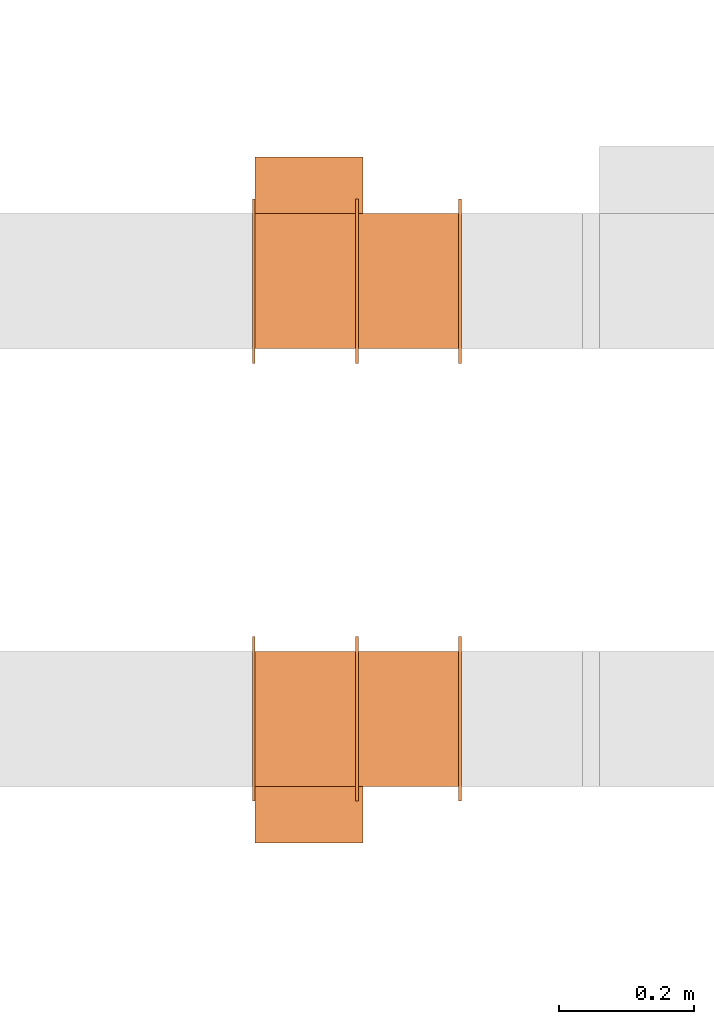
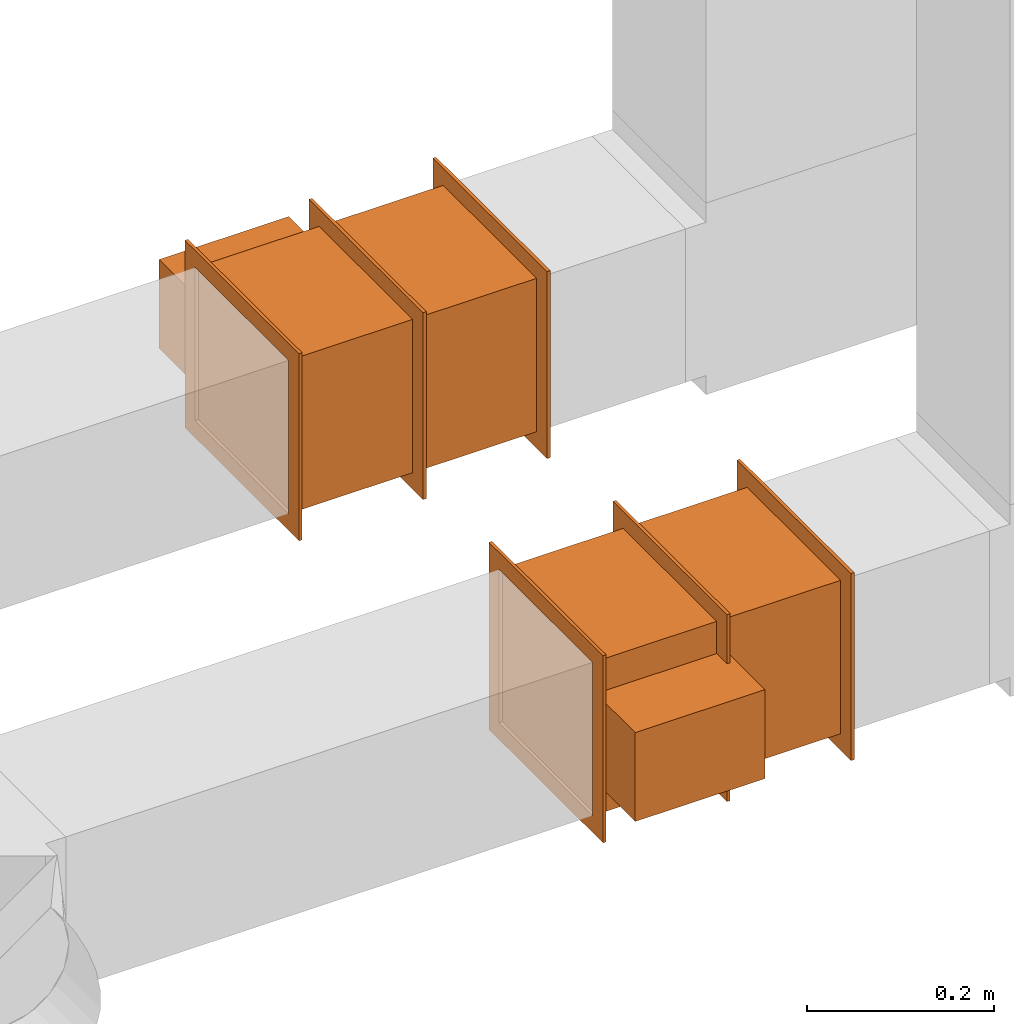
# One storey, part 12 of 12: 2 proxies.
"""IFC2X3 building model written with IfcOpenShell, lengths in millimetres."""

from ifc_helpers import new_model, entity, si_unit, converted_unit, derived_unit, direction, frame, frame_2d, origin, origin_2d_with_axis, place, context, subcontext, project, spatial, polyline, rectangle, outline, extrude, source, transform, mapped, type_object, type_shapes, element, save


model = new_model("IFC2X3")

# Units and contexts
model_context = context("Model", 3, precision=0.01, world=origin(), true_north=direction((6.12303176911189e-17, 1.0)))
body_context = subcontext(model_context, "Body", "Model", "MODEL_VIEW")
ifc_project = project(units=[si_unit("LENGTHUNIT", "METRE", prefix="MILLI"), si_unit("AREAUNIT", "SQUARE_METRE"), si_unit("VOLUMEUNIT", "CUBIC_METRE"), converted_unit("PLANEANGLEUNIT", "DEGREE", entity("IfcRatioMeasure", 0.0174532925199433), si_unit("PLANEANGLEUNIT", "RADIAN"), dimensions=[0, 0, 0, 0, 0, 0, 0]), si_unit("MASSUNIT", "GRAM", prefix="KILO"), derived_unit("MASSDENSITYUNIT", [(si_unit("MASSUNIT", "GRAM", prefix="KILO"), 1), (si_unit("LENGTHUNIT", "METRE"), -3)]), si_unit("TIMEUNIT", "SECOND"), si_unit("FREQUENCYUNIT", "HERTZ"), si_unit("THERMODYNAMICTEMPERATUREUNIT", "DEGREE_CELSIUS"), derived_unit("THERMALTRANSMITTANCEUNIT", [(si_unit("MASSUNIT", "GRAM", prefix="KILO"), 1), (si_unit("THERMODYNAMICTEMPERATUREUNIT", "KELVIN"), -1), (si_unit("TIMEUNIT", "SECOND"), -3)]), derived_unit("VOLUMETRICFLOWRATEUNIT", [(si_unit("LENGTHUNIT", "METRE"), 3), (si_unit("TIMEUNIT", "SECOND"), -1)]), si_unit("ELECTRICCURRENTUNIT", "AMPERE"), si_unit("ELECTRICVOLTAGEUNIT", "VOLT"), si_unit("POWERUNIT", "WATT"), si_unit("FORCEUNIT", "NEWTON", prefix="KILO"), si_unit("ILLUMINANCEUNIT", "LUX"), si_unit("LUMINOUSFLUXUNIT", "LUMEN"), si_unit("LUMINOUSINTENSITYUNIT", "CANDELA"), derived_unit("USERDEFINED", [(si_unit("MASSUNIT", "GRAM", prefix="KILO"), -1), (si_unit("LENGTHUNIT", "METRE"), -2), (si_unit("TIMEUNIT", "SECOND"), 3), (si_unit("LUMINOUSFLUXUNIT", "LUMEN"), 1)]), derived_unit("LINEARVELOCITYUNIT", [(si_unit("LENGTHUNIT", "METRE"), 1), (si_unit("TIMEUNIT", "SECOND"), -1)]), si_unit("PRESSUREUNIT", "PASCAL"), derived_unit("USERDEFINED", [(si_unit("LENGTHUNIT", "METRE"), -2), (si_unit("MASSUNIT", "GRAM", prefix="KILO"), 1), (si_unit("TIMEUNIT", "SECOND"), -2)])], contexts=[model_context])

# Site, building, storey
site_placement = place(None, origin())
site = spatial("IfcSite", under=ifc_project, at=site_placement, CompositionType="ELEMENT")
building_placement = place(site_placement, origin())
building = spatial("IfcBuilding", under=site, at=building_placement, CompositionType="ELEMENT")
storey_placement = place(building_placement, frame((0.0, 0.0, 4000.0)))
storey = spatial("IfcBuildingStorey", under=building, at=storey_placement, Name="01 Level", CompositionType="ELEMENT", Elevation=4000.0)

# Proxies
building_element_proxy_type_1 = type_object("IfcBuildingElementProxyType", Name="WK", PredefinedType="NOTDEFINED")
shared_shape_1 = source(origin(), body_context, "Body", "SweptSolid", [
    extrude(outline(polyline([(-122.0, -122.0), (122.0, -122.0), (122.0, 122.0), (-122.0, 122.0), (-122.0, -122.0)]), holes=[polyline([(-100.0, -100.0), (-100.0, 100.0), (100.0, 100.0), (100.0, -100.0), (-100.0, -100.0)])]), frame((151.0, 0.0, 0.0), z_axis=(1.0, 0.0, 0.0), x_axis=(0.0, 0.0, -1.0)), (0.0, 0.0, 1.0), 4.0),
    extrude(outline(polyline([(-122.0, -122.0), (122.0, -122.0), (122.0, 122.0), (-122.0, 122.0), (-122.0, -122.0)]), holes=[polyline([(-100.0, -100.0), (-100.0, 100.0), (100.0, 100.0), (100.0, -100.0), (-100.0, -100.0)])]), frame((-155.0, 0.0, 0.0), z_axis=(1.0, 0.0, 0.0), x_axis=(0.0, -1.0, 0.0)), (0.0, 0.0, 1.0), 4.0),
    extrude(outline(polyline([(-122.0, -122.0), (122.0, -122.0), (122.0, 122.0), (-122.0, 122.0), (-122.0, -122.0)]), holes=[polyline([(-100.0, -100.0), (-100.0, 100.0), (100.0, 100.0), (100.0, -100.0), (-100.0, -100.0)])]), frame((-2.0, 0.0, 0.0), z_axis=(1.0, 0.0, 0.0), x_axis=(0.0, -1.0, 0.0)), (0.0, 0.0, 1.0), 4.0),
    extrude(rectangle(XDim=302.0, YDim=200.0, at=origin_2d_with_axis()), frame((0.0, 0.0, -100.0), z_axis=(0.0, 0.0, 1.0), x_axis=(-1.0, 0.0, 0.0)), (0.0, 0.0, 1.0), 200.0),
    extrude(rectangle(XDim=84.0, YDim=160.0, at=frame_2d((-1.06581410364015e-14, 0.0), x_axis=(1.0, 0.0))), frame((71.0, -142.0, -58.0), z_axis=(0.0, 0.0, 1.0), x_axis=(0.0, -1.0, 0.0)), (0.0, 0.0, 1.0), 116.0),
])
type_shapes(building_element_proxy_type_1, [shared_shape_1])
proxy_1_placement = place(storey_placement, frame((24095.9900708518, -69156.0352293172, 3000.0), z_axis=(0.0, 0.0, -1.0), x_axis=(-1.0, 0.0, 0.0)))
element("IfcBuildingElementProxy", 1, at=proxy_1_placement, inside=storey, type_object=building_element_proxy_type_1, Name="WK25-0001:WK", ObjectType="WK25-0001:WK", context=body_context, shape_type="MappedRepresentation", body=[
    mapped(shared_shape_1, transform((0.0, 0.0, 0.0), scale=1.0)),
])
building_element_proxy_type_2 = type_object("IfcBuildingElementProxyType", Name="WK", PredefinedType="NOTDEFINED")
shared_shape_2 = source(origin(), body_context, "Body", "SweptSolid", [
    extrude(outline(polyline([(-122.0, -122.0), (122.0, -122.0), (122.0, 122.0), (-122.0, 122.0), (-122.0, -122.0)]), holes=[polyline([(-100.0, -100.0), (-100.0, 100.0), (100.0, 100.0), (100.0, -100.0), (-100.0, -100.0)])]), frame((151.0, 0.0, 0.0), z_axis=(1.0, 0.0, 0.0), x_axis=(0.0, -1.0, 0.0)), (0.0, 0.0, 1.0), 4.0),
    extrude(outline(polyline([(-122.0, -122.0), (122.0, -122.0), (122.0, 122.0), (-122.0, 122.0), (-122.0, -122.0)]), holes=[polyline([(-100.0, -100.0), (-100.0, 100.0), (100.0, 100.0), (100.0, -100.0), (-100.0, -100.0)])]), frame((-155.0, 0.0, 0.0), z_axis=(1.0, 0.0, 0.0), x_axis=(0.0, 0.0, -1.0)), (0.0, 0.0, 1.0), 4.0),
    extrude(outline(polyline([(-122.0, -122.0), (122.0, -122.0), (122.0, 122.0), (-122.0, 122.0), (-122.0, -122.0)]), holes=[polyline([(-100.0, -100.0), (-100.0, 100.0), (100.0, 100.0), (100.0, -100.0), (-100.0, -100.0)])]), frame((-2.0, 0.0, 0.0), z_axis=(1.0, 0.0, 0.0), x_axis=(0.0, 0.0, -1.0)), (0.0, 0.0, 1.0), 4.0),
    extrude(rectangle(XDim=200.0, YDim=302.0, at=origin_2d_with_axis()), frame((0.0, 0.0, -100.0), z_axis=(0.0, 0.0, 1.0), x_axis=(0.0, 1.0, 0.0)), (0.0, 0.0, 1.0), 200.0),
    extrude(rectangle(XDim=160.0, YDim=84.0, at=frame_2d((0.0, -1.06581410364015e-14), x_axis=(1.0, 0.0))), frame((71.0, 142.0, -58.0)), (0.0, 0.0, 1.0), 116.0),
])
type_shapes(building_element_proxy_type_2, [shared_shape_2])
proxy_2_placement = place(storey_placement, frame((24095.9900708518, -68506.4439409626, 3000.0), z_axis=(0.0, 0.0, -1.0), x_axis=(-1.0, 0.0, 0.0)))
element("IfcBuildingElementProxy", 2, at=proxy_2_placement, inside=storey, type_object=building_element_proxy_type_2, Name="WK25-0001:WK", ObjectType="WK25-0001:WK", context=body_context, shape_type="MappedRepresentation", body=[
    mapped(shared_shape_2, transform((0.0, 0.0, 0.0), scale=1.0)),
])

save(model, "model.ifc")
